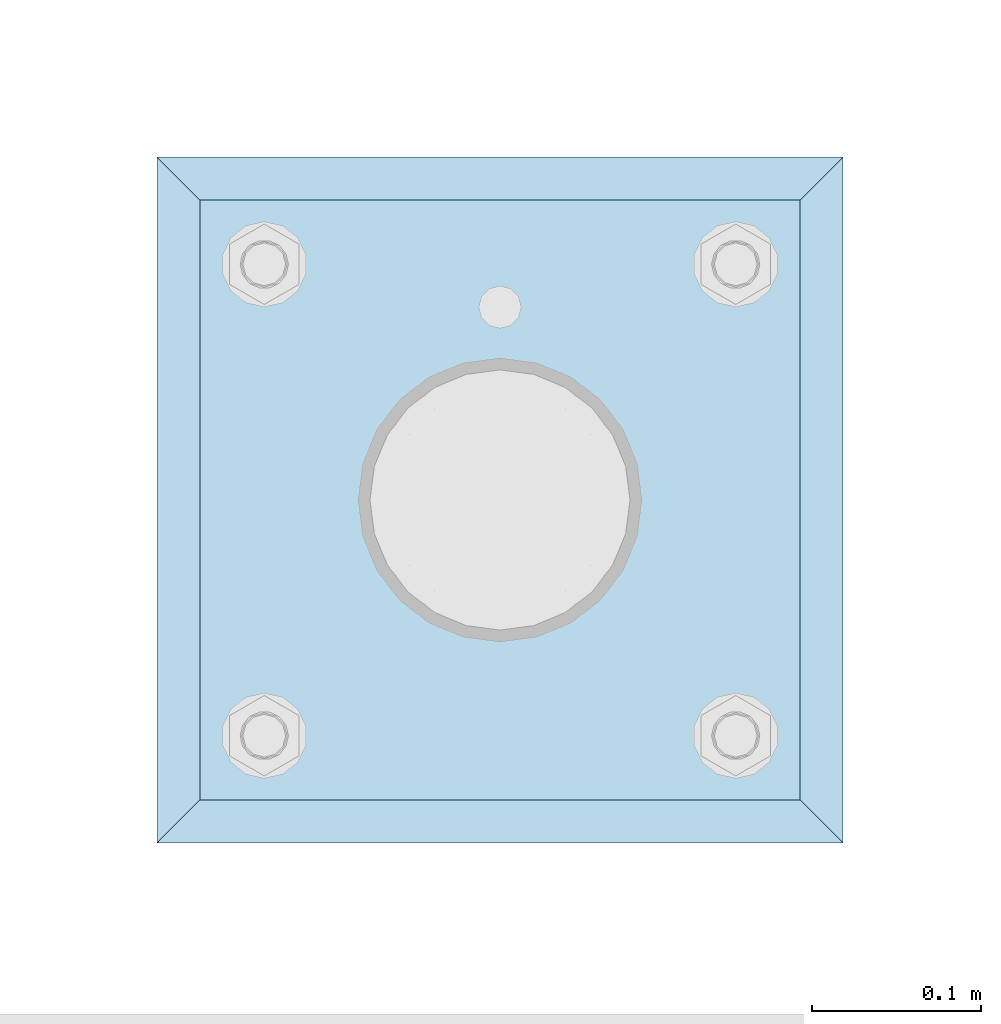
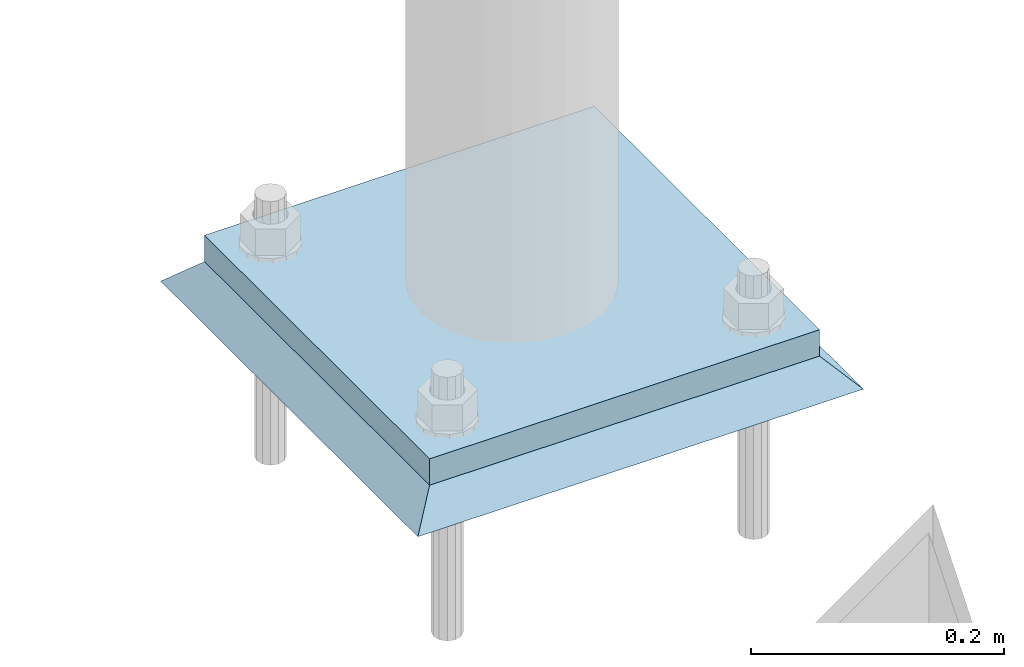
# One storey, part 3431 of 3843: 2 plates, 2 elements without a shape of their own.
"""IFC2X3 building model written with IfcOpenShell, lengths in millimetres."""

import ifcopenshell
import ifcopenshell.guid

model = None  # the IFC model being written
_history = None  # IfcOwnerHistory: only IFC2X3 demands one
_inside = {}  # id of a spatial element -> (the spatial element, [elements in it])
_under = {}  # id of a project, library or spatial element -> (it, [spatial elements below it])
_declared = {}  # id of a project -> (the project, [libraries it declares])
_typed = {}  # id of a type object -> (the type object, [elements of that type])
_made_of = {}  # id of a material, layer set ... -> (it, [elements and type objects made of it])


def new_model(schema):
    """Start an empty IFC model of exactly this schema.

    Asked for "IFC4X3", IfcOpenShell would pick the latest addendum, in which some entities
    have other attributes; the version numbers below select the first issue.
    IFC2X3 requires an IfcOwnerHistory on every rooted entity: one is made here for all.
    """
    global model, _history
    if schema == "IFC4X3":
        model = ifcopenshell.file(schema_version=(4, 3, 0, 0))
    else:
        model = ifcopenshell.file(schema=schema)
    _inside.clear()
    _under.clear()
    _declared.clear()
    _typed.clear()
    _made_of.clear()
    _history = None
    if model.schema == "IFC2X3":
        org = make("IfcOrganization", Name="unknown")
        user = make(
            "IfcPersonAndOrganization",
            ThePerson=make("IfcPerson", FamilyName="unknown"),
            TheOrganization=org,
        )
        app = make(
            "IfcApplication",
            ApplicationDeveloper=org,
            Version="unknown",
            ApplicationFullName="unknown",
            ApplicationIdentifier="unknown",
        )
        _history = make(
            "IfcOwnerHistory",
            OwningUser=user,
            OwningApplication=app,
            ChangeAction="ADDED",
            CreationDate=0,
        )
    return model


def make(cls, **values):
    """One entity of the class cls with the attributes given. An attribute that is None is left unset."""
    return model.create_entity(
        cls, **{name: value for name, value in values.items() if value is not None}
    )


def rooted(cls, **values):
    """An entity with a GlobalId (a new one), such as an element, a storey or a relation."""
    return make(cls, GlobalId=ifcopenshell.guid.new(), OwnerHistory=_history, **values)


def si_unit(unit_type, name, prefix=None):
    """IfcSIUnit, for example si_unit("LENGTHUNIT", "METRE", prefix="MILLI")."""
    return make("IfcSIUnit", UnitType=unit_type, Prefix=prefix, Name=name)


def assignment(units):
    """IfcUnitAssignment: the units of a project."""
    return None if units is None else make("IfcUnitAssignment", Units=units)


def point(xyz):
    """IfcCartesianPoint."""
    return None if xyz is None else make("IfcCartesianPoint", Coordinates=xyz)


def direction(xyz):
    """IfcDirection."""
    return None if xyz is None else make("IfcDirection", DirectionRatios=xyz)


def frame(location, z_axis=None, x_axis=None):
    """IfcAxis2Placement3D, a coordinate frame: its origin and axes. An axis left out is left unset."""
    return make(
        "IfcAxis2Placement3D",
        Location=point(location),
        Axis=direction(z_axis),
        RefDirection=direction(x_axis),
    )


def origin_with_axes():
    """The frame at (0, 0, 0) with the z axis (0, 0, 1) and the x axis (1, 0, 0) written out."""
    return frame((0.0, 0.0, 0.0), z_axis=(0.0, 0.0, 1.0), x_axis=(1.0, 0.0, 0.0))


def place(relative_to, where):
    """IfcLocalPlacement: puts the frame where relative to a parent placement (None: the world)."""
    return make(
        "IfcLocalPlacement", PlacementRelTo=relative_to, RelativePlacement=where
    )


def context(
    kind, dimensions, precision=None, world=None, true_north=None, identifier=None
):
    """IfcGeometricRepresentationContext, for example the 3D "Model" context."""
    return make(
        "IfcGeometricRepresentationContext",
        ContextIdentifier=identifier,
        ContextType=kind,
        CoordinateSpaceDimension=dimensions,
        Precision=precision,
        WorldCoordinateSystem=world,
        TrueNorth=true_north,
    )


def subcontext(parent, identifier, kind, view, scale=None):
    """IfcGeometricRepresentationSubContext, for example "Body" below "Model"."""
    return make(
        "IfcGeometricRepresentationSubContext",
        ContextIdentifier=identifier,
        ContextType=kind,
        ParentContext=parent,
        TargetScale=scale,
        TargetView=view,
    )


def project(units=None, contexts=None):
    """IfcProject with its units and contexts."""
    return rooted(
        "IfcProject",
        Name="project",
        RepresentationContexts=contexts,
        UnitsInContext=assignment(units),
    )


def spatial(cls, under=None, at=None, **own):
    """A site, building, storey or space (cls), placed at a placement, below another one or the project."""
    s = rooted(cls, ObjectPlacement=at, **own)
    if under is not None:
        _under.setdefault(under.id(), (under, []))[1].append(s)
    return s


def faces_of(points, faces, orient=None, outer=None):
    """IfcFace entities. A face is a list of loops; a loop is a list of indices into points, from 0.

    orient and outer hold one flag for each loop. By default every Orientation is true, the
    first loop of a face is its IfcFaceOuterBound and the others are IfcFaceBound.
    """
    made = []
    for i, loops in enumerate(faces):
        bounds = []
        for j, loop in enumerate(loops):
            is_outer = j == 0 if outer is None else outer[i][j]
            bounds.append(
                make(
                    "IfcFaceOuterBound" if is_outer else "IfcFaceBound",
                    Bound=make("IfcPolyLoop", Polygon=[points[k] for k in loop]),
                    Orientation=True if orient is None else orient[i][j],
                )
            )
        made.append(make("IfcFace", Bounds=bounds))
    return made


def faceted_brep(points, faces, orient=None, outer=None, voids=None):
    """IfcFacetedBrep: a solid bounded by flat faces; with voids (closed shells), ...WithVoids."""
    shared = [point(p) for p in points]
    hull = make("IfcClosedShell", CfsFaces=faces_of(shared, faces, orient, outer))
    if voids is None:
        return make("IfcFacetedBrep", Outer=hull)
    return make(
        "IfcFacetedBrepWithVoids",
        Outer=hull,
        Voids=[
            make(cls, CfsFaces=faces_of(shared, fs, o, b)) for cls, fs, o, b in voids
        ],
    )


def shape(context_of_items, identifier, shape_type, items):
    """IfcShapeRepresentation: the items that make up one representation, for example the "Body"."""
    return make(
        "IfcShapeRepresentation",
        ContextOfItems=context_of_items,
        RepresentationIdentifier=identifier,
        RepresentationType=shape_type,
        Items=items,
    )


def material(Name=None, Category=None):
    """IfcMaterial."""
    return make("IfcMaterial", Name=Name, Category=Category)


def made_of(thing, what):
    """Note that an element or type object is made of a material, layer set ...; save() writes the relation."""
    if what is not None:
        _made_of.setdefault(what.id(), (what, []))[1].append(thing)
    return thing


def type_object(cls, material=None, **own):
    """A type object (cls), such as IfcWallType, which elements share."""
    return made_of(rooted(cls, **own), material)


def element(
    cls,
    number,
    at=None,
    inside=None,
    cuts=None,
    type_object=None,
    material=None,
    context=None,
    identifier="Body",
    shape_type=None,
    held_by="IfcProductDefinitionShape",
    body=None,
    shapes=None,
    **own,
):
    """One element of the class cls, such as IfcWall. Its Tag is "e" and its number.

    at: its placement. inside: the storey or other place that contains it. cuts: it is an
    opening in that element (IfcRelVoidsElement). A single representation is given by context,
    identifier, shape_type and body (its items); several are given by shapes. held_by: the class
    of the entity that holds the representations. save() writes the other relations.
    """
    e = rooted(cls, Tag="e%d" % number, ObjectPlacement=at, **own)
    if body is not None:
        shapes = [shape(context, identifier, shape_type, body)]
    if shapes is not None:
        e.Representation = make(held_by, Representations=shapes)
    if inside is not None:
        _inside.setdefault(inside.id(), (inside, []))[1].append(e)
    if cuts is not None:
        rooted(
            "IfcRelVoidsElement", RelatingBuildingElement=cuts, RelatedOpeningElement=e
        )
    if type_object is not None:
        _typed.setdefault(type_object.id(), (type_object, []))[1].append(e)
    return made_of(e, material)


def aggregate(whole, parts):
    """IfcRelAggregates: a whole, such as a stair, and the parts it consists of."""
    return rooted("IfcRelAggregates", RelatingObject=whole, RelatedObjects=parts)


def save(model, path):
    """Write the relations noted so far, then the file.

    IfcRelAggregates (storeys below a building ...), IfcRelContainedInSpatialStructure (elements
    in a storey), IfcRelDefinesByType, IfcRelAssociatesMaterial and IfcRelDeclares: one each for
    every whole, place, type object, material and project.
    """
    for whole, parts in _under.values():
        aggregate(whole, parts)
    for where, things in _inside.values():
        rooted(
            "IfcRelContainedInSpatialStructure",
            RelatedElements=things,
            RelatingStructure=where,
        )
    for kind, things in _typed.values():
        rooted("IfcRelDefinesByType", RelatedObjects=things, RelatingType=kind)
    for what, things in _made_of.values():
        rooted("IfcRelAssociatesMaterial", RelatedObjects=things, RelatingMaterial=what)
    for by, libraries in _declared.values():
        rooted("IfcRelDeclares", RelatingContext=by, RelatedDefinitions=libraries)
    model.write(path)


model = new_model("IFC2X3")

# Units and contexts
model_context = context("Model", 3, precision=1e-05, world=origin_with_axes())
body_context = subcontext(model_context, "Body", "Model", "MODEL_VIEW")
ifc_project = project(units=[si_unit("LENGTHUNIT", "METRE", prefix="MILLI"), si_unit("AREAUNIT", "SQUARE_METRE"), si_unit("VOLUMEUNIT", "CUBIC_METRE"), si_unit("MASSUNIT", "GRAM", prefix="KILO"), si_unit("TIMEUNIT", "SECOND"), si_unit("PLANEANGLEUNIT", "RADIAN"), si_unit("SOLIDANGLEUNIT", "STERADIAN"), si_unit("THERMODYNAMICTEMPERATUREUNIT", "DEGREE_CELSIUS"), si_unit("LUMINOUSINTENSITYUNIT", "LUMEN")], contexts=[model_context])

# Site, building, storey
site_placement = place(None, origin_with_axes())
site = spatial("IfcSite", under=ifc_project, at=site_placement, CompositionType="ELEMENT")
building_placement = place(site_placement, origin_with_axes())
building = spatial("IfcBuilding", under=site, at=building_placement, Name="Undefined", CompositionType="ELEMENT")
storey_placement = place(building_placement, origin_with_axes())
storey = spatial("IfcBuildingStorey", under=building, at=storey_placement, Name="Undefined", CompositionType="ELEMENT", Elevation=0.0)

# Assembly, plate
assembly_1_placement = place(storey_placement, origin_with_axes())
assembly_1 = element("IfcElementAssembly", 1, at=assembly_1_placement, inside=storey, Name="PIPE_BOLLARD", AssemblyPlace="NOTDEFINED", PredefinedType="RIGID_FRAME")
ifc_material_1 = material(Name="STEEL/A572-50")
plate_type_1 = type_object("IfcPlateType", PredefinedType="NOTDEFINED")
plate_1_placement = place(assembly_1_placement, frame((42672.0, 92951.3, 30518.1), z_axis=(0.0, 1.0, 0.0), x_axis=(1.0, 0.0, 0.0)))
plate_1 = element("IfcPlate", 2, at=plate_1_placement, type_object=plate_type_1, material=ifc_material_1, Name="PLATE", context=body_context, shape_type="Brep", body=[
    faceted_brep([(0.0, -12.6999999999971, 0.0), (0.0, -12.7000000000007, 355.600000000006), (0.0, 12.7000000000007, 355.600000000006), (0.0, 12.6999999999971, 0.0), (355.599999999999, -12.7000000000007, 355.600000000006), (355.599999999999, 12.7000000000007, 355.600000000006), (355.599999999999, -12.7000000000007, 0.0), (355.599999999999, 12.7000000000007, 0.0)], [[[0, 1, 2, 3]], [[1, 4, 5, 2]], [[4, 6, 7, 5]], [[6, 0, 3, 7]], [[5, 7, 3, 2]], [[6, 4, 1, 0]]]),
])
aggregate(assembly_1, [plate_1])

assembly_2_placement = place(storey_placement, origin_with_axes())
assembly_2 = element("IfcElementAssembly", 3, at=assembly_2_placement, inside=storey, Name="GROUT", AssemblyPlace="NOTDEFINED", PredefinedType="REINFORCEMENT_UNIT")
ifc_material_2 = material(Name="CONCRETE/Concrete_Undefined")
plate_type_2 = type_object("IfcPlateType", PredefinedType="NOTDEFINED")
plate_2_placement = place(assembly_2_placement, frame((42646.6, 92925.9, 30492.7), z_axis=(0.0, 1.0, 0.0), x_axis=(1.0, 0.0, 0.0)))
plate_2 = element("IfcPlate", 4, at=plate_2_placement, type_object=plate_type_2, material=ifc_material_2, Name="GROUT", context=body_context, shape_type="Brep", body=[
    faceted_brep([(25.4000000001906, -12.6999999998552, 380.999999999505), (0.0, 12.7000000000007, 406.399999999994), (0.0, 12.6999999999971, 0.0), (25.4000000001906, -12.6999999999898, 25.4000000004453), (380.999999999833, -12.6999999998588, 25.4000000004453), (406.400000000001, 12.7000000000007, 0.0), (406.400000000001, 12.7000000000007, 406.399999999994), (380.999999999833, -12.6999999999898, 380.999999999505)], [[[0, 1, 2, 3]], [[4, 5, 6, 7]], [[4, 7, 0, 3]], [[5, 4, 3, 2]], [[6, 5, 2, 1]], [[7, 6, 1, 0]]]),
])
aggregate(assembly_2, [plate_2])

save(model, "model.ifc")
